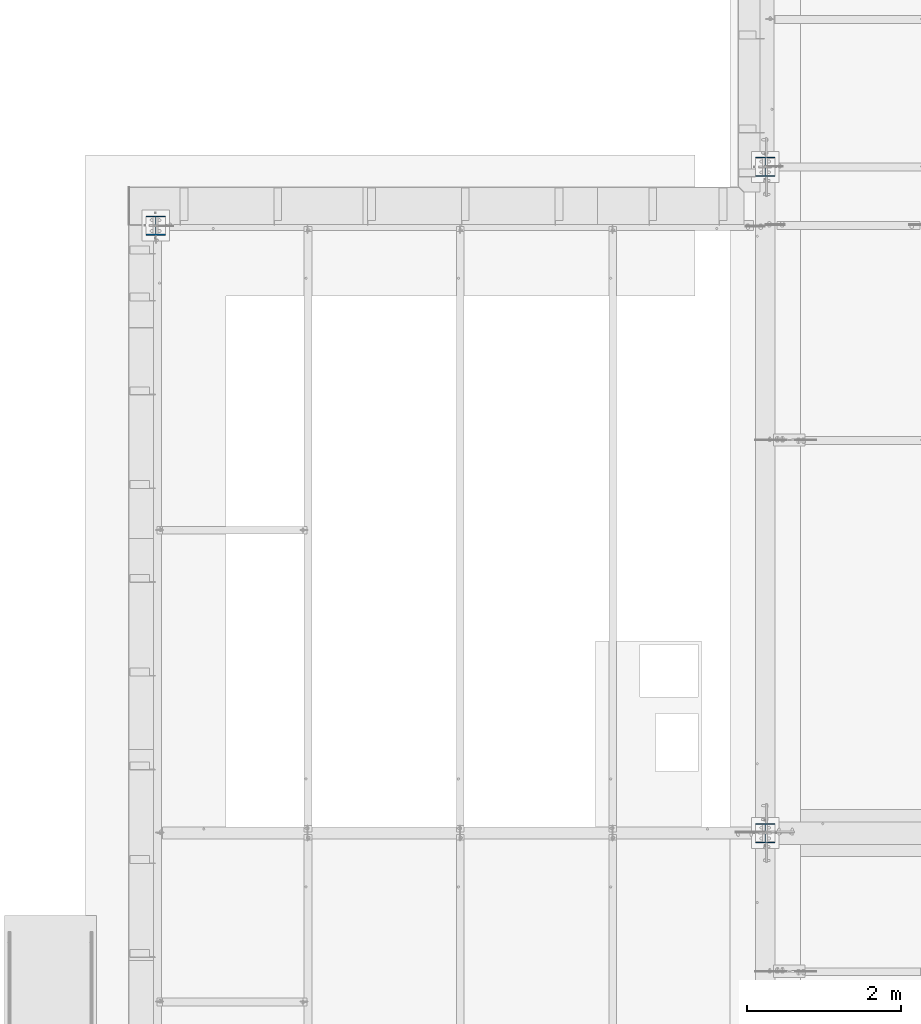
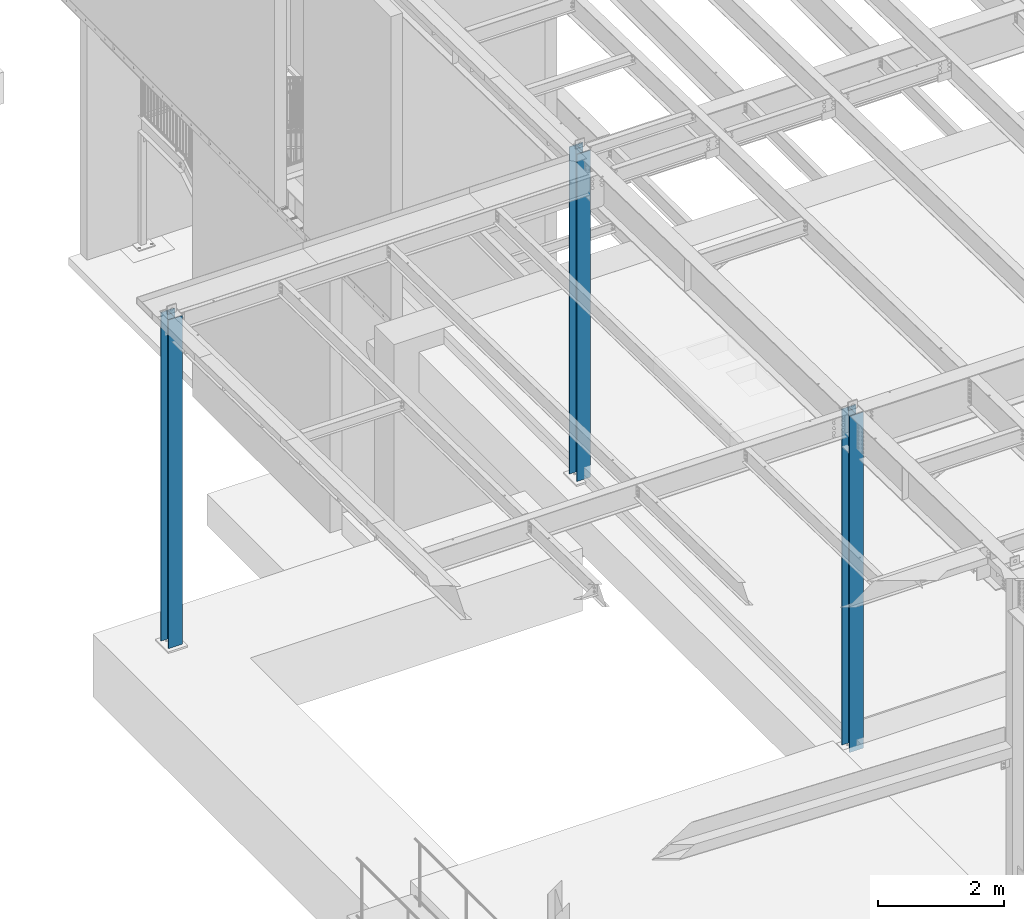
# One storey, part 898 of 1763: 3 columns, 3 elements without a shape of their own.
"""IFC2X3 building model written with IfcOpenShell, lengths in millimetres."""

from ifc_helpers import new_model, si_unit, frame, origin_with_axes, place, context, subcontext, project, spatial, faceted_brep, material, type_object, element, aggregate, save


model = new_model("IFC2X3")

# Units and contexts
model_context = context("Model", 3, precision=1e-05, world=origin_with_axes())
body_context = subcontext(model_context, "Body", "Model", "MODEL_VIEW")
ifc_project = project(units=[si_unit("LENGTHUNIT", "METRE", prefix="MILLI"), si_unit("AREAUNIT", "SQUARE_METRE"), si_unit("VOLUMEUNIT", "CUBIC_METRE"), si_unit("MASSUNIT", "GRAM", prefix="KILO"), si_unit("TIMEUNIT", "SECOND"), si_unit("PLANEANGLEUNIT", "RADIAN"), si_unit("SOLIDANGLEUNIT", "STERADIAN"), si_unit("THERMODYNAMICTEMPERATUREUNIT", "DEGREE_CELSIUS"), si_unit("LUMINOUSINTENSITYUNIT", "LUMEN")], contexts=[model_context])

# Site, building, storey
site_placement = place(None, origin_with_axes())
site = spatial("IfcSite", under=ifc_project, at=site_placement, CompositionType="ELEMENT")
building_placement = place(site_placement, origin_with_axes())
building = spatial("IfcBuilding", under=site, at=building_placement, Name="Undefined", CompositionType="ELEMENT")
storey_placement = place(building_placement, origin_with_axes())
storey = spatial("IfcBuildingStorey", under=building, at=storey_placement, Name="Undefined", CompositionType="ELEMENT", Elevation=0.0)

# Assembly, column
assembly_1_placement = place(storey_placement, origin_with_axes())
assembly_1 = element("IfcElementAssembly", 1, at=assembly_1_placement, inside=storey, Name="COLUMN", AssemblyPlace="NOTDEFINED", PredefinedType="RIGID_FRAME")
ifc_material = material(Name="STEEL/A992")
column_type = type_object("IfcColumnType", Name="W10X49", PredefinedType="NOTDEFINED")
column_1_placement = place(assembly_1_placement, frame((-87375.4372736983, 22352.0, 5029.2), z_axis=(0.0, 1.0, 0.0), x_axis=(0.0, 0.0, 1.0)))
column_1 = element("IfcColumn", 2, at=column_1_placement, type_object=column_type, material=ifc_material, Name="COLUMN", ObjectType="W10X49", context=body_context, shape_type="Brep", body=[
    faceted_brep([(69.8500000000085, 127.0, -127.0), (69.8500000000085, 127.0, -112.712500000001), (6408.76515893517, 127.0, -112.712500000001), (6408.76515893517, 127.0, -127.0), (69.8500000000085, 3.96875, -112.712500000001), (6408.76515893517, 3.96875, -112.712500000001), (69.8500000000085, 3.96875, 112.712500000001), (6408.76515893517, 3.96875, 112.712500000001), (69.8500000000085, 127.0, 112.712500000001), (6408.76515893517, 127.0, 112.712500000001), (69.8500000000085, 127.0, 127.0), (6408.76515893517, 127.0, 127.0), (69.8500000000085, -127.0, 127.0), (6408.76515893517, -127.0, 127.0), (69.8500000000085, -127.0, 112.712500000001), (6408.76515893517, -127.0, 112.712500000001), (69.8500000000085, -3.96875, 112.712500000001), (6408.76515893517, -3.96875, 112.712500000001), (69.8500000000085, -3.96875, -112.712500000001), (6408.76515893517, -3.96875, -112.712500000001), (69.8500000000085, -127.0, -112.712500000001), (6408.76515893517, -127.0, -112.712500000001), (69.8500000000085, -127.0, -127.0), (6408.76515893517, -127.0, -127.0)], [[[0, 1, 2, 3]], [[1, 4, 5, 2]], [[4, 6, 7, 5]], [[6, 8, 9, 7]], [[8, 10, 11, 9]], [[10, 12, 13, 11]], [[12, 14, 15, 13]], [[14, 16, 17, 15]], [[16, 18, 19, 17]], [[18, 20, 21, 19]], [[20, 22, 23, 21]], [[22, 0, 3, 23]], [[5, 7, 9, 11, 13, 15, 17, 19, 21, 23, 3, 2]], [[22, 20, 18, 16, 14, 12, 10, 8, 6, 4, 1, 0]]]),
])
aggregate(assembly_1, [column_1])

assembly_2_placement = place(storey_placement, origin_with_axes())
assembly_2 = element("IfcElementAssembly", 3, at=assembly_2_placement, inside=storey, Name="COLUMN", AssemblyPlace="NOTDEFINED", PredefinedType="RIGID_FRAME")
column_2_placement = place(assembly_2_placement, frame((-95300.2372736984, 21590.0, 5029.2), z_axis=(0.0, 1.0, 0.0), x_axis=(0.0, 0.0, 1.0)))
column_2 = element("IfcColumn", 4, at=column_2_placement, type_object=column_type, material=ifc_material, Name="COLUMN", ObjectType="W10X49", context=body_context, shape_type="Brep", body=[
    faceted_brep([(69.8500000000085, 127.0, -127.0), (69.8500000000085, 127.0, -112.712500000001), (6435.72500000002, 127.0, -112.712500000001), (6435.72500000002, 127.0, -127.0), (69.8500000000085, 3.96875, -112.712500000001), (6435.72500000002, 3.96875, -112.712500000001), (69.8500000000085, 3.96875, 112.712500000001), (6435.72500000002, 3.96875, 112.712500000001), (69.8500000000085, 127.0, 112.712500000001), (6435.72500000002, 127.0, 112.712500000001), (69.8500000000085, 127.0, 127.0), (6435.72500000002, 127.0, 127.0), (69.8500000000085, -127.0, 127.0), (6435.72500000002, -127.0, 127.0), (69.8500000000085, -127.0, 112.712500000001), (6435.72500000002, -127.0, 112.712500000001), (69.8500000000085, -3.96875, 112.712500000001), (6435.72500000002, -3.96875, 112.712500000001), (69.8500000000085, -3.96875, -112.712500000001), (6435.72500000002, -3.96875, -112.712500000001), (69.8500000000085, -127.0, -112.712500000001), (6435.72500000002, -127.0, -112.712500000001), (69.8500000000085, -127.0, -127.0), (6435.72500000002, -127.0, -127.0)], [[[0, 1, 2, 3]], [[1, 4, 5, 2]], [[4, 6, 7, 5]], [[6, 8, 9, 7]], [[8, 10, 11, 9]], [[10, 12, 13, 11]], [[12, 14, 15, 13]], [[14, 16, 17, 15]], [[16, 18, 19, 17]], [[18, 20, 21, 19]], [[20, 22, 23, 21]], [[22, 0, 3, 23]], [[5, 7, 9, 11, 13, 15, 17, 19, 21, 23, 3, 2]], [[22, 20, 18, 16, 14, 12, 10, 8, 6, 4, 1, 0]]]),
])
aggregate(assembly_2, [column_2])

assembly_3_placement = place(storey_placement, origin_with_axes())
assembly_3 = element("IfcElementAssembly", 5, at=assembly_3_placement, inside=storey, Name="COLUMN", AssemblyPlace="NOTDEFINED", PredefinedType="RIGID_FRAME")
column_3_placement = place(assembly_3_placement, frame((-87375.4372736983, 13690.6, 5029.2), z_axis=(0.0, 1.0, 0.0), x_axis=(0.0, 0.0, 1.0)))
column_3 = element("IfcColumn", 6, at=column_3_placement, type_object=column_type, material=ifc_material, Name="COLUMN", ObjectType="W10X49", context=body_context, shape_type="Brep", body=[
    faceted_brep([(69.8500000000085, 127.0, -127.0), (69.8500000000085, 127.0, -112.712500000001), (6583.51178810887, 127.0, -112.7125), (6583.51178810887, 127.0, -127.0), (69.8500000000085, 3.96875, -112.712500000001), (6583.51178810887, 3.96875, -112.7125), (69.8500000000085, 3.96875, 112.712500000001), (6583.51178810887, 3.96875, 112.7125), (69.8500000000085, 127.0, 112.712500000001), (6583.51178810887, 127.0, 112.7125), (69.8500000000085, 127.0, 127.0), (6583.51178810887, 127.0, 127.0), (69.8500000000085, -127.0, 127.0), (6583.51178810887, -127.0, 127.0), (69.8500000000085, -127.0, 112.712500000001), (6583.51178810887, -127.0, 112.7125), (69.8500000000085, -3.96875, 112.712500000001), (6583.51178810887, -3.96875, 112.7125), (69.8500000000085, -3.96875, -112.712500000001), (6583.51178810887, -3.96875, -112.7125), (69.8500000000085, -127.0, -112.712500000001), (6583.51178810887, -127.0, -112.7125), (69.8500000000085, -127.0, -127.0), (6583.51178810887, -127.0, -127.0)], [[[0, 1, 2, 3]], [[1, 4, 5, 2]], [[4, 6, 7, 5]], [[6, 8, 9, 7]], [[8, 10, 11, 9]], [[10, 12, 13, 11]], [[12, 14, 15, 13]], [[14, 16, 17, 15]], [[16, 18, 19, 17]], [[18, 20, 21, 19]], [[20, 22, 23, 21]], [[22, 0, 3, 23]], [[5, 7, 9, 11, 13, 15, 17, 19, 21, 23, 3, 2]], [[22, 20, 18, 16, 14, 12, 10, 8, 6, 4, 1, 0]]]),
])
aggregate(assembly_3, [column_3])

save(model, "model.ifc")
